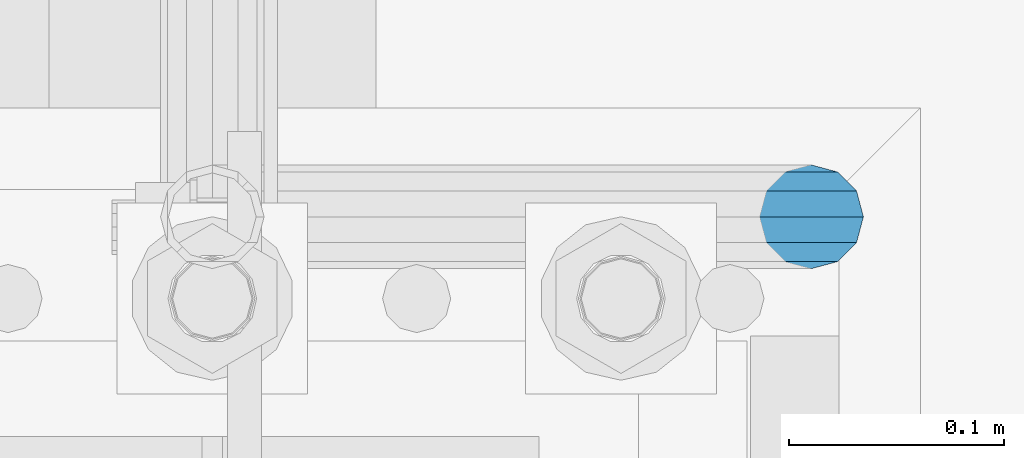
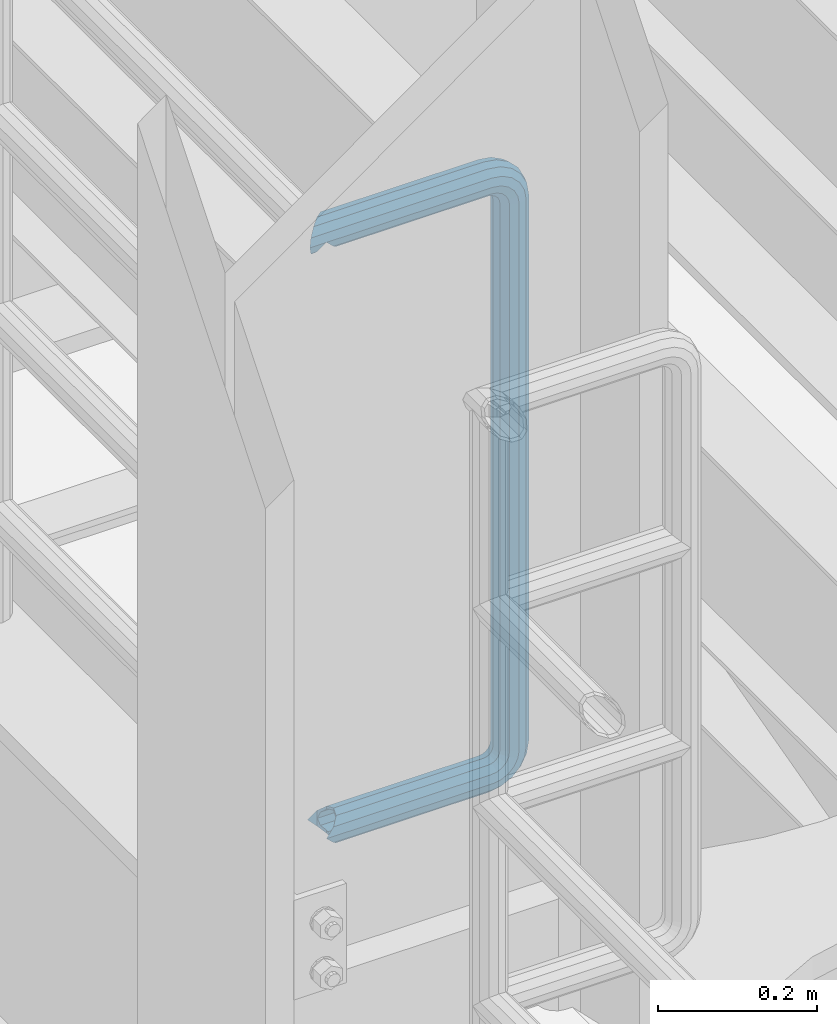
# One storey, part 958 of 1876: 1 beam, 1 element without a shape of its own.
"""IFC2X3 building model written with IfcOpenShell, lengths in millimetres."""

from ifc_helpers import new_model, si_unit, frame, origin_with_axes, place, context, subcontext, project, spatial, faceted_brep, material, type_object, element, aggregate, save


model = new_model("IFC2X3")

# Units and contexts
model_context = context("Model", 3, precision=1e-05, world=origin_with_axes())
body_context = subcontext(model_context, "Body", "Model", "MODEL_VIEW")
ifc_project = project(units=[si_unit("LENGTHUNIT", "METRE", prefix="MILLI"), si_unit("AREAUNIT", "SQUARE_METRE"), si_unit("VOLUMEUNIT", "CUBIC_METRE"), si_unit("MASSUNIT", "GRAM", prefix="KILO"), si_unit("TIMEUNIT", "SECOND"), si_unit("PLANEANGLEUNIT", "RADIAN"), si_unit("SOLIDANGLEUNIT", "STERADIAN"), si_unit("THERMODYNAMICTEMPERATUREUNIT", "DEGREE_CELSIUS"), si_unit("LUMINOUSINTENSITYUNIT", "LUMEN")], contexts=[model_context])

# Site, building, storey
site_placement = place(None, origin_with_axes())
site = spatial("IfcSite", under=ifc_project, at=site_placement, CompositionType="ELEMENT")
building_placement = place(site_placement, origin_with_axes())
building = spatial("IfcBuilding", under=site, at=building_placement, Name="Undefined", CompositionType="ELEMENT")
storey_placement = place(building_placement, origin_with_axes())
storey = spatial("IfcBuildingStorey", under=building, at=storey_placement, Name="Undefined", CompositionType="ELEMENT", Elevation=0.0)

# Assembly, beam
assembly_placement = place(storey_placement, origin_with_axes())
assembly = element("IfcElementAssembly", 1, at=assembly_placement, inside=storey, Name="RAIL", AssemblyPlace="NOTDEFINED", PredefinedType="RIGID_FRAME")
ifc_material = material()
beam_type = type_object("IfcBeamType", Name="PIPE1-1/2SCH40", PredefinedType="NOTDEFINED")
beam_placement = place(assembly_placement, frame((-5.00222085975111e-12, -4356.1, 9229.725), z_axis=(0.0, 0.0, 1.0), x_axis=(1.0, 0.0, 0.0)))
beam = element("IfcBeam", 2, at=beam_placement, type_object=beam_type, material=ifc_material, Name="RAIL", ObjectType="PIPE1-1/2SCH40", context=body_context, shape_type="Brep", body=[
    faceted_brep([(16.4810964966631, 16.4810964966564, -11.4500249345219), (16.481099754581, 16.4810997545774, -16.4810932387409), (20.8971929933249, 12.0650000000005, -20.8971929933177), (20.8971929933249, 12.0650000000005, -15.8661214311796), (0.0, -24.1299999999992, 0.0), (12.0650000000014, -20.8971929933186, 0.0), (12.0650000000064, -20.8971929933177, -12.0649999999987), (-12.0650000000096, -20.8971929933177, -12.0649999999987), (-12.0649999999986, -20.8971929933186, 0.0), (-16.481093238739, -16.4810932387427, -16.4810997545756), (-16.4810964966554, -16.4810964966618, -11.4500249345183), (-15.2545715621367, -17.7076214311801, -10.2235000000001), (-12.5151929933171, -20.4470000000001, 0.0), (12.5151929933249, -20.4470000000001, 0.0), (20.8971929933249, -12.0650000000005, -15.8661214311796), (20.8971929933249, -12.0650000000005, -20.8971929933177), (15.2545715621445, -17.7076214311801, -10.2235000000001), (24.1300000000063, 0.0, -20.4470000000001), (24.1300000000063, 0.0, -24.130000000001), (21.3906214311868, -10.2235000000001, -17.7076214311819), (21.3906214311868, 10.2235000000001, -17.7076214311819), (1.20714750983051e-12, 24.1299999999974, -914.399963378906), (12.0650000000014, 20.8971929933159, -926.464963378905), (12.0650000000014, 20.8971929933177, -902.334963378908), (12.0650000000014, -20.8971929933195, -902.334963378908), (12.0650000000014, -20.8971929933195, -926.464963378905), (1.52133659548828e-12, -24.130000000001, -914.399963378906), (20.8971929933199, -12.0650000000023, -893.502770385589), (20.8971929933199, -12.0650000000005, -898.533841947723), (15.2545715621378, -17.7076214311819, -904.176463378906), (12.5151929933181, -20.4470000000019, -914.399963378906), (15.2545715621376, -17.7076214311819, -924.623463378906), (20.8971929933199, -12.0650000000005, -930.26608481009), (20.8971929933199, -12.0650000000023, -935.297156372224), (24.1300000000014, -1.81898940354586e-12, -934.846963378906), (24.1300000000014, -1.81898940354586e-12, -938.529963378907), (21.3906214311813, -10.2235000000019, -932.107584810088), (21.3906214311823, 10.2234999999982, -932.107584810088), (20.8971929933199, 12.0650000000005, -930.266084810086), (20.8971929933199, 12.0649999999987, -935.297156372224), (15.2545715621413, 17.7076214311783, -924.623463378906), (12.5151929933216, 20.4469999999983, -914.399963378906), (15.2545715621411, 17.7076214311783, -904.176463378906), (20.8971929933199, 12.0650000000005, -898.533841947727), (20.8971929933199, 12.0649999999987, -893.502770385589), (21.3906214311822, 10.2234999999982, -896.692341947724), (24.1300000000014, 0.0, -893.952963378906), (24.1300000000014, 0.0, -890.269963378905), (21.3906214311814, -10.2235000000019, -896.692341947724), (241.299995422363, -20.8971929933177, 12.0649999999987), (241.299995422363, -24.1299999999992, 0.0), (253.073542436527, -24.1299999999992, -1.86474665447167), (256.801832473661, -20.8971929933177, 9.60975021462946), (241.299995422363, -12.0650000000005, 20.8971929933177), (259.531130206197, -12.0650000000005, 18.0096649141014), (241.299995422363, 0.0, 24.130000000001), (260.530122510796, 0.0, 21.084247083727), (241.299995422363, 12.0650000000005, 20.8971929933177), (259.531130206197, 12.0650000000005, 18.0096649141014), (241.299995422363, 20.8971929933177, 12.0649999999987), (256.801832473661, 20.8971929933177, 9.60975021462946), (241.299995422363, 24.1299999999992, 0.0), (253.073542436527, 24.1299999999992, -1.86474665447167), (241.299995422363, 20.8971929933177, -12.0649999999987), (249.345252399393, 20.8971929933177, -13.3392435235728), (241.299995422363, 12.0650000000005, -20.8971929933177), (246.615954666858, 12.0650000000005, -21.7391582230448), (241.299995422363, 0.0, -24.130000000001), (245.616962362259, 0.0, -24.8137403926739), (241.299995422363, -12.0650000000005, -20.8971929933177), (246.615954666858, -12.0650000000005, -21.7391582230448), (241.299995422363, -20.8971929933177, -12.0649999999987), (249.345252399393, -20.8971929933177, -13.3392435235728), (267.334993896485, 20.8971929933177, -38.0999984741211), (279.399993896485, 24.1299999999992, -38.0999984741211), (279.399993896484, 24.1299999999992, -876.299964904785), (267.334993896484, 20.8971929933177, -876.299964904785), (291.464993896486, 20.8971929933177, -38.0999984741211), (291.464993896484, 20.8971929933177, -876.299964904785), (300.297186889804, 12.0650000000005, -38.0999984741211), (300.297186889803, 12.0650000000005, -876.299964904785), (303.529993896486, 0.0, -38.0999984741211), (303.529993896484, 0.0, -876.299964904785), (300.297186889804, -12.0650000000005, -38.0999984741211), (300.297186889803, -12.0650000000005, -876.299964904785), (291.464993896486, -20.8971929933177, -38.0999984741211), (291.464993896484, -20.8971929933177, -876.299964904785), (279.399993896484, -24.1299999999992, -38.0999984741211), (279.399993896484, -24.1299999999992, -876.299964904785), (267.334993896485, -20.8971929933177, -38.0999984741211), (267.334993896484, -20.8971929933177, -876.299964904785), (258.502800903167, -12.0650000000005, -38.0999984741211), (258.502800903166, -12.0650000000005, -876.299964904785), (255.269993896485, 0.0, -38.0999984741211), (255.269993896484, 0.0, -876.299964904785), (258.502800903167, 12.0650000000005, -38.0999984741211), (258.502800903166, 12.0650000000005, -876.299964904785), (257.660835673438, 12.0650000000005, -881.615924149282), (254.586253503809, 0.0, -880.616931844681), (257.660835673438, -12.0650000000005, -881.615924149282), (266.06075037291, -20.8971929933177, -884.345221881817), (277.535247242011, -24.130000000001, -888.073511918952), (289.009744111112, -20.8971929933195, -891.801801956084), (297.409658810584, -12.0650000000005, -894.531099688622), (300.484240980214, 0.0, -895.53009199322), (297.409658810584, 12.0650000000005, -894.531099688622), (289.009744111112, 20.8971929933177, -891.801801956084), (277.535247242011, 24.1299999999992, -888.073511918952), (266.06075037291, 20.8971929933177, -884.345221881817), (241.299995422364, -1.81898940354586e-12, -938.529963378911), (241.299995422364, -12.0650000000005, -935.297156372228), (241.299995422364, -20.8971929933195, -926.464963378909), (241.299995422363, -24.130000000001, -914.399963378906), (241.299995422363, -20.8971929933195, -902.334963378908), (241.299995422363, -12.0650000000005, -893.502770385589), (241.299995422363, 0.0, -890.269963378909), (241.299995422364, 20.8971929933177, -926.464963378909), (241.299995422364, 12.0649999999987, -935.297156372228), (241.299995422364, 24.1299999999992, -914.39996337891), (241.299995422363, 20.8971929933177, -902.334963378908), (241.299995422363, 12.0649999999987, -893.502770385589), (260.530122510801, 0.0, -935.484210462637), (259.531130206202, 12.0649999999987, -932.409628293008), (259.531130206201, -12.0650000000005, -932.409628293008), (256.801832473666, -20.8971929933195, -924.009713593536), (253.07354243653, -24.130000000001, -912.535216724435), (249.345252399395, -20.8971929933195, -901.060719855333), (246.615954666859, -12.0650000000005, -892.660805155861), (245.61696236226, 0.0, -889.586222986232), (246.615954666859, 12.0649999999987, -892.660805155861), (249.345252399395, 20.8971929933177, -901.060719855333), (253.07354243653, 24.1299999999992, -912.535216724435), (256.801832473666, 20.8971929933177, -924.009713593536), (275.977674493594, 12.0649999999987, -924.029695422345), (270.786241706733, 20.8971929933177, -916.884301193139), (277.877870775644, 0.0, -926.645091230272), (275.977674493608, -12.0650000000005, -924.029695422334), (270.786241706733, -20.8971929933195, -916.884301193139), (263.694612637823, -24.130000000001, -907.123511156005), (256.602983568912, -20.8971929933195, -897.362721118872), (251.411550782037, -12.0650000000005, -890.21732688968), (249.511354500001, 0.0, -887.601931081743), (251.411550782037, 12.0650000000005, -890.21732688968), (256.602983568912, 20.8971929933177, -897.362721118872), (263.694612637823, 24.1299999999992, -907.123511156005), (281.884331710718, 20.8971929933177, -905.786211189152), (272.123541673585, 24.1299999999992, -898.694582120243), (289.029725939912, 12.0650000000005, -910.977643976028), (291.645121747852, 0.0, -912.877840258065), (289.029725939912, -12.0650000000005, -910.977643976028), (281.884331710718, -20.8971929933195, -905.786211189152), (272.123541673585, -24.130000000001, -898.694582120243), (262.362751636451, -20.8971929933195, -891.602953051333), (255.217357407258, -12.0650000000005, -886.411520264461), (252.601961599318, 0.0, -884.511323982424), (255.217357407258, 12.0650000000005, -886.411520264461), (262.362751636451, 20.8971929933177, -891.602953051333), (266.060750372911, 20.8971929933177, -30.0547414970897), (257.660835673439, 12.0650000000005, -32.7840392296275), (277.535247242011, 24.1299999999992, -26.3264514599541), (289.009744111112, 20.8971929933177, -22.5981614228222), (297.409658810584, 12.0650000000005, -19.8688636902843), (300.484240980213, 0.0, -18.8698713856866), (297.409658810584, -12.0650000000005, -19.8688636902843), (289.009744111112, -20.8971929933177, -22.5981614228222), (277.535247242011, -24.1299999999992, -26.3264514599541), (266.060750372911, -20.8971929933177, -30.0547414970897), (257.660835673439, -12.0650000000005, -32.7840392296275), (254.58625350381, 0.0, -33.7830315342253), (255.217357407257, 12.0650000000005, -27.9884431144455), (252.601961599318, 0.0, -29.8886393964822), (262.362751636451, 20.8971929933177, -22.7970103275729), (272.123541673583, 24.1299999999992, -15.7053812586601), (281.884331710716, 20.8971929933177, -8.61375218975081), (289.029725939909, 12.0650000000005, -3.42231940287456), (291.645121747848, 0.0, -1.52212312084157), (289.029725939909, -12.0650000000005, -3.42231940287456), (281.884331710716, -20.8971929933177, -8.61375218975081), (272.123541673583, -24.1299999999992, -15.7053812586601), (262.362751636451, -20.8971929933177, -22.7970103275729), (255.217357407257, -12.0650000000005, -27.9884431144455), (249.511354500002, 0.0, -26.7980322971671), (251.411550782037, -12.0650000000005, -24.1826364892258), (251.411550782037, 12.0650000000005, -24.1826364892258), (256.602983568912, 20.8971929933177, -17.037242260034), (263.694612637822, 24.1299999999992, -7.27645222290084), (270.786241706732, 20.8971929933177, 2.48433781423228), (275.977674493607, 12.0650000000005, 9.62973204342416), (277.877870775642, 0.0, 12.2451278513654), (275.977674493607, -12.0650000000005, 9.62973204342416), (270.786241706732, -20.8971929933177, 2.48433781423228), (263.694612637822, -24.1299999999992, -7.27645222290084), (256.602983568912, -20.8971929933177, -17.037242260034), (20.8971929933232, 20.8971929933177, -12.0649999999987), (24.1300000000047, 24.1299999999992, 0.0), (20.8971929933232, 20.8971929933177, 12.0649999999987), (12.0650000000041, 12.0650000000005, 20.8971929933177), (-1.45519152283669e-11, 0.0, 24.130000000001), (-12.0649999999951, -12.0650000000005, 20.8971929933177), (-20.8971929933141, -20.8971929933177, 12.0649999999987), (-24.1299999999956, -24.1299999999992, 0.0), (-20.8971929933141, -20.8971929933177, -12.0649999999987), (-17.7076214311755, -17.7076214311801, -10.2235000000001), (-20.4469999999956, -20.4470000000001, 0.0), (-17.7076214311755, -17.7076214311801, 10.2235000000001), (241.299995422363, -17.7076214311801, 10.2235000000001), (241.299995422363, -20.4470000000001, 0.0), (241.299995422363, -17.7076214311801, -10.2235000000001), (241.299995422363, -10.2235000000001, -17.7076214311819), (241.299995422363, 0.0, -20.4470000000001), (241.299995422363, 0.0, 20.4470000000001), (241.299995422363, -10.2235000000001, 17.7076214311819), (-10.2234999999955, -10.2235000000001, 17.7076214311819), (-1.45519152283669e-11, 0.0, 20.4470000000001), (241.299995422363, 10.2235000000001, 17.7076214311819), (10.2235000000046, 10.2235000000001, 17.7076214311819), (241.299995422363, 17.7076214311801, 10.2235000000001), (17.7076214311846, 17.7076214311801, 10.2235000000001), (241.299995422363, 20.4470000000001, 0.0), (20.4470000000047, 20.4470000000001, 0.0), (241.299995422363, 17.7076214311801, -10.2235000000001), (17.7076214311846, 17.7076214311801, -10.2235000000001), (241.299995422363, 10.2235000000001, -17.7076214311819), (258.545498388721, -10.2235000000001, 14.9762020957387), (256.23277767852, -17.7076214311801, 7.85837963987069), (253.073542436527, -20.4470000000001, -1.86474665447167), (249.914307194535, -17.7076214311801, -11.5878729488177), (247.601586484334, -10.2235000000001, -18.7056954046857), (246.755071952542, 0.0, -21.31099924316), (247.601586484334, 10.2235000000001, -18.7056954046857), (249.914307194535, 17.7076214311801, -11.5878729488177), (253.073542436527, 20.4470000000001, -1.86474665447167), (256.23277767852, 17.7076214311801, 7.85837963987069), (258.545498388721, 10.2235000000001, 14.9762020957387), (259.392012920513, 0.0, 17.5815059342131), (275.713057691449, 0.0, 9.26551826108334), (274.10289136825, -10.2235000000001, 7.04931444488102), (274.10289136825, 10.2235000000001, 7.04931444488102), (269.703835164635, 17.7076214311801, 0.994533019089431), (263.694612637822, 20.4470000000001, -7.27645222290084), (257.685390111009, 17.7076214311801, -15.5474374648911), (253.286333907394, 10.2235000000001, -21.6022188906827), (251.676167584195, 0.0, -23.818422706885), (253.286333907394, -10.2235000000001, -21.6022188906827), (257.685390111009, -17.7076214311801, -15.5474374648911), (263.694612637822, -20.4470000000001, -7.27645222290084), (269.703835164635, -17.7076214311801, 0.994533019089431), (286.449308341364, -10.2235000000001, -5.29710252823133), (280.394526915574, -17.7076214311801, -9.69615873184739), (288.665512157566, 0.0, -3.68693620503473), (286.449308341364, 10.2235000000001, -5.29710252823133), (280.394526915574, 17.7076214311801, -9.69615873184739), (272.123541673583, 20.4470000000001, -15.7053812586601), (263.852556431592, 17.7076214311801, -21.7146037854764), (257.797775005802, 10.2235000000001, -26.1136599890888), (255.581571189601, 0.0, -27.723826312289), (257.797775005802, -10.2235000000001, -26.1136599890888), (263.852556431592, -17.7076214311801, -21.7146037854764), (272.123541673583, -20.4470000000001, -15.7053812586601), (287.258373536355, -17.7076214311801, -23.1672162179639), (277.535247242011, -20.4470000000001, -26.3264514599541), (294.376195992223, -10.2235000000001, -20.8544955077632), (296.981499830698, 0.0, -20.00798097597), (294.376195992223, 10.2235000000001, -20.8544955077632), (287.258373536355, 17.7076214311801, -23.1672162179639), (277.535247242011, 20.4470000000001, -26.3264514599541), (267.812120947668, 17.7076214311801, -29.485686701948), (260.6942984918, 10.2235000000001, -31.7984074121487), (258.088994653325, 0.0, -32.6449219439419), (260.6942984918, -10.2235000000001, -31.7984074121487), (267.812120947668, -17.7076214311801, -29.485686701948), (279.399993896484, -20.4470000000001, -38.0999984741211), (269.176493896485, -17.7076214311801, -38.0999984741211), (289.623493896486, -17.7076214311801, -38.0999984741211), (297.107615327666, -10.2235000000001, -38.0999984741211), (299.846993896486, 0.0, -38.0999984741211), (297.107615327666, 10.2235000000001, -38.0999984741211), (289.623493896486, 17.7076214311801, -38.0999984741211), (279.399993896485, 20.4470000000001, -38.0999984741211), (269.176493896485, 17.7076214311801, -38.0999984741211), (261.692372465305, 10.2235000000001, -38.0999984741211), (258.952993896485, 0.0, -38.0999984741211), (261.692372465305, -10.2235000000001, -38.0999984741211), (269.176493896484, -17.7076214311801, -876.299964904785), (261.692372465304, -10.2235000000001, -876.299964904785), (258.952993896484, 0.0, -876.299964904785), (261.692372465304, 10.2235000000001, -876.299964904785), (269.176493896484, 17.7076214311801, -876.299964904785), (279.399993896484, 20.4470000000001, -876.299964904785), (289.623493896484, 17.7076214311801, -876.299964904785), (297.107615327665, 10.2235000000001, -876.299964904785), (299.846993896484, 0.0, -876.299964904785), (297.107615327665, -10.2235000000001, -876.299964904785), (289.623493896484, -17.7076214311801, -876.299964904785), (279.399993896484, -20.4470000000001, -876.299964904785), (277.535247242011, -20.4470000000001, -888.073511918952), (267.812120947667, -17.7076214311801, -884.914276676958), (260.694298491799, -10.2235000000001, -882.601555966758), (258.088994653324, 0.0, -881.755041434964), (260.694298491799, 10.2235000000001, -882.601555966758), (267.812120947668, 17.7076214311801, -884.914276676958), (277.535247242011, 20.4470000000001, -888.073511918952), (287.258373536355, 17.7076214311801, -891.232747160942), (294.376195992223, 10.2235000000001, -893.545467871143), (296.981499830699, 0.0, -894.391982402936), (294.376195992223, -10.2235000000001, -893.545467871143), (287.258373536355, -17.7076214311801, -891.232747160942), (280.394526915577, -17.7076214311801, -904.703804647055), (272.123541673585, -20.4470000000001, -898.694582120243), (286.449308341367, -10.2235000000001, -909.102860850671), (288.665512157569, 0.0, -910.713027173868), (286.449308341367, 10.2235000000001, -909.102860850671), (280.394526915577, 17.7076214311801, -904.703804647055), (272.123541673585, 20.4470000000001, -898.694582120243), (263.852556431593, 17.7076214311801, -892.68535959343), (257.797775005802, 10.2235000000001, -888.286303389817), (255.581571189601, 0.0, -886.676137066617), (257.797775005802, -10.2235000000001, -888.286303389817), (263.852556431593, -17.7076214311801, -892.68535959343), (263.694612637823, -20.4470000000001, -907.123511156005), (257.685390111009, -17.7076214311801, -898.852525914015), (269.703835164636, -17.7076214311801, -915.394496397999), (274.102891368238, -10.2235000000001, -921.449277823798), (275.71305769145, 0.0, -923.66548163999), (274.102891368251, 10.2235000000001, -921.449277823787), (269.703835164636, 17.7076214311801, -915.394496397999), (263.694612637823, 20.4470000000001, -907.123511156005), (257.685390111009, 17.7076214311801, -898.852525914015), (253.286333907394, 10.2235000000001, -892.797744488227), (251.676167584195, 0.0, -890.581540672025), (253.286333907394, -10.2235000000001, -892.797744488227), (249.914307194537, -17.7076214311801, -902.812090430092), (247.601586484335, -10.2235000000001, -895.694267974224), (253.07354243653, -20.4470000000001, -912.535216724435), (256.232777678524, -17.7076214311819, -922.258343018777), (258.545498388725, -10.2235000000001, -929.376165474645), (259.392012920517, 0.0, -931.981469313119), (258.545498388725, 10.2235000000001, -929.376165474645), (256.232777678524, 17.7076214311801, -922.258343018777), (253.07354243653, 20.4470000000001, -912.535216724435), (249.914307194537, 17.7076214311801, -902.812090430092), (247.601586484335, 10.2235000000001, -895.694267974224), (246.755071952543, 0.0, -893.088964135746), (241.299995422363, -10.2235000000001, -896.692341947728), (241.299995422363, 0.0, -893.95296337891), (241.299995422363, -17.7076214311819, -904.17646337891), (241.299995422363, -20.4470000000001, -914.399963378906), (241.299995422364, -17.7076214311819, -924.62346337891), (241.299995422364, -10.2235000000001, -932.107584810088), (241.299995422364, -1.81898940354586e-12, -934.84696337891), (241.299995422364, 10.2234999999982, -932.107584810088), (241.299995422364, 17.7076214311801, -924.62346337891), (241.299995422364, 20.4470000000001, -914.39996337891), (241.299995422363, 17.7076214311801, -904.17646337891), (241.299995422363, 10.2235000000001, -896.692341947728)], [[[0, 1, 2, 3]], [[4, 5, 6]], [[7, 8, 4]], [[9, 10, 11, 12, 8, 7]], [[13, 5, 4, 8, 12]], [[14, 15, 6, 5, 13, 16]], [[17, 18, 15, 14, 19]], [[20, 3, 2, 18, 17]], [[21, 22, 23]], [[24, 25, 26]], [[27, 28, 29, 30, 31, 32, 33, 25, 24]], [[34, 35, 33, 32, 36]], [[37, 38, 39, 35, 34]], [[23, 22, 39, 38, 40, 41, 42, 43, 44]], [[44, 43, 45, 46, 47]], [[47, 46, 48, 28, 27]], [[49, 50, 51, 52]], [[53, 49, 52, 54]], [[55, 53, 54, 56]], [[57, 55, 56, 58]], [[59, 57, 58, 60]], [[61, 59, 60, 62]], [[63, 61, 62, 64]], [[65, 63, 64, 66]], [[67, 65, 66, 68]], [[69, 67, 68, 70]], [[71, 69, 70, 72]], [[73, 74, 75, 76]], [[74, 77, 78, 75]], [[77, 79, 80, 78]], [[79, 81, 82, 80]], [[81, 83, 84, 82]], [[83, 85, 86, 84]], [[85, 87, 88, 86]], [[87, 89, 90, 88]], [[89, 91, 92, 90]], [[91, 93, 94, 92]], [[93, 95, 96, 94]], [[94, 96, 97, 98]], [[92, 94, 98, 99]], [[90, 92, 99, 100]], [[88, 90, 100, 101]], [[86, 88, 101, 102]], [[84, 86, 102, 103]], [[82, 84, 103, 104]], [[80, 82, 104, 105]], [[78, 80, 105, 106]], [[75, 78, 106, 107]], [[76, 75, 107, 108]], [[109, 110, 33, 35]], [[110, 111, 25, 33]], [[111, 112, 26, 25]], [[112, 113, 24, 26]], [[113, 114, 27, 24]], [[114, 115, 47, 27]], [[116, 117, 39, 22]], [[118, 116, 22, 21]], [[119, 118, 21, 23]], [[120, 119, 23, 44]], [[115, 120, 44, 47]], [[117, 109, 35, 39]], [[121, 109, 117, 122]], [[123, 110, 109, 121]], [[124, 111, 110, 123]], [[125, 112, 111, 124]], [[126, 113, 112, 125]], [[127, 114, 113, 126]], [[128, 115, 114, 127]], [[129, 120, 115, 128]], [[130, 119, 120, 129]], [[131, 118, 119, 130]], [[132, 116, 118, 131]], [[122, 117, 116, 132]], [[133, 122, 132, 134]], [[135, 121, 122, 133]], [[136, 123, 121, 135]], [[137, 124, 123, 136]], [[138, 125, 124, 137]], [[139, 126, 125, 138]], [[140, 127, 126, 139]], [[141, 128, 127, 140]], [[142, 129, 128, 141]], [[143, 130, 129, 142]], [[144, 131, 130, 143]], [[134, 132, 131, 144]], [[145, 134, 144, 146]], [[147, 133, 134, 145]], [[148, 135, 133, 147]], [[149, 136, 135, 148]], [[150, 137, 136, 149]], [[151, 138, 137, 150]], [[152, 139, 138, 151]], [[153, 140, 139, 152]], [[154, 141, 140, 153]], [[155, 142, 141, 154]], [[156, 143, 142, 155]], [[146, 144, 143, 156]], [[107, 146, 156, 108]], [[106, 145, 146, 107]], [[105, 147, 145, 106]], [[104, 148, 147, 105]], [[103, 149, 148, 104]], [[102, 150, 149, 103]], [[101, 151, 150, 102]], [[100, 152, 151, 101]], [[99, 153, 152, 100]], [[98, 154, 153, 99]], [[97, 155, 154, 98]], [[108, 156, 155, 97]], [[96, 76, 108, 97]], [[95, 73, 76, 96]], [[157, 73, 95, 158]], [[159, 74, 73, 157]], [[160, 77, 74, 159]], [[161, 79, 77, 160]], [[162, 81, 79, 161]], [[163, 83, 81, 162]], [[164, 85, 83, 163]], [[165, 87, 85, 164]], [[166, 89, 87, 165]], [[167, 91, 89, 166]], [[168, 93, 91, 167]], [[158, 95, 93, 168]], [[169, 158, 168, 170]], [[171, 157, 158, 169]], [[172, 159, 157, 171]], [[173, 160, 159, 172]], [[174, 161, 160, 173]], [[175, 162, 161, 174]], [[176, 163, 162, 175]], [[177, 164, 163, 176]], [[178, 165, 164, 177]], [[179, 166, 165, 178]], [[180, 167, 166, 179]], [[170, 168, 167, 180]], [[181, 170, 180, 182]], [[183, 169, 170, 181]], [[184, 171, 169, 183]], [[185, 172, 171, 184]], [[186, 173, 172, 185]], [[187, 174, 173, 186]], [[188, 175, 174, 187]], [[189, 176, 175, 188]], [[190, 177, 176, 189]], [[191, 178, 177, 190]], [[192, 179, 178, 191]], [[182, 180, 179, 192]], [[70, 182, 192, 72]], [[68, 181, 182, 70]], [[66, 183, 181, 68]], [[64, 184, 183, 66]], [[62, 185, 184, 64]], [[60, 186, 185, 62]], [[58, 187, 186, 60]], [[56, 188, 187, 58]], [[54, 189, 188, 56]], [[52, 190, 189, 54]], [[51, 191, 190, 52]], [[72, 192, 191, 51]], [[50, 71, 72, 51]], [[71, 50, 4, 6]], [[69, 71, 6, 15]], [[67, 69, 15, 18]], [[65, 67, 18, 2]], [[193, 63, 65, 2, 1]], [[61, 63, 193, 194]], [[59, 61, 194, 195]], [[57, 59, 195, 196]], [[55, 57, 196, 197]], [[53, 55, 197, 198]], [[49, 53, 198, 199]], [[4, 50, 49, 199, 200]], [[200, 201, 7, 4]], [[201, 9, 7]], [[202, 11, 10]], [[202, 203, 12, 11]], [[203, 204, 205, 206, 13, 12]], [[206, 207, 16, 13]], [[16, 207, 208, 19, 14]], [[208, 209, 17, 19]], [[210, 211, 212, 213]], [[214, 210, 213, 215]], [[216, 214, 215, 217]], [[218, 216, 217, 219]], [[220, 218, 219, 221]], [[222, 220, 221, 0, 3, 20]], [[209, 222, 20, 17]], [[221, 219, 217, 215, 213, 212, 204, 203, 202, 10, 9, 201, 200, 199, 198, 197, 196, 195, 194, 193, 1, 0]], [[211, 205, 204, 212]], [[205, 211, 223, 224]], [[206, 205, 224, 225]], [[207, 206, 225, 226]], [[208, 207, 226, 227]], [[209, 208, 227, 228]], [[222, 209, 228, 229]], [[220, 222, 229, 230]], [[218, 220, 230, 231]], [[216, 218, 231, 232]], [[214, 216, 232, 233]], [[210, 214, 233, 234]], [[211, 210, 234, 223]], [[234, 235, 236, 223]], [[233, 237, 235, 234]], [[232, 238, 237, 233]], [[231, 239, 238, 232]], [[230, 240, 239, 231]], [[229, 241, 240, 230]], [[228, 242, 241, 229]], [[227, 243, 242, 228]], [[226, 244, 243, 227]], [[225, 245, 244, 226]], [[224, 246, 245, 225]], [[223, 236, 246, 224]], [[236, 247, 248, 246]], [[235, 249, 247, 236]], [[237, 250, 249, 235]], [[238, 251, 250, 237]], [[239, 252, 251, 238]], [[240, 253, 252, 239]], [[241, 254, 253, 240]], [[242, 255, 254, 241]], [[243, 256, 255, 242]], [[244, 257, 256, 243]], [[245, 258, 257, 244]], [[246, 248, 258, 245]], [[248, 259, 260, 258]], [[247, 261, 259, 248]], [[249, 262, 261, 247]], [[250, 263, 262, 249]], [[251, 264, 263, 250]], [[252, 265, 264, 251]], [[253, 266, 265, 252]], [[254, 267, 266, 253]], [[255, 268, 267, 254]], [[256, 269, 268, 255]], [[257, 270, 269, 256]], [[258, 260, 270, 257]], [[260, 271, 272, 270]], [[259, 273, 271, 260]], [[261, 274, 273, 259]], [[262, 275, 274, 261]], [[263, 276, 275, 262]], [[264, 277, 276, 263]], [[265, 278, 277, 264]], [[266, 279, 278, 265]], [[267, 280, 279, 266]], [[268, 281, 280, 267]], [[269, 282, 281, 268]], [[270, 272, 282, 269]], [[282, 272, 283, 284]], [[281, 282, 284, 285]], [[280, 281, 285, 286]], [[279, 280, 286, 287]], [[278, 279, 287, 288]], [[277, 278, 288, 289]], [[276, 277, 289, 290]], [[275, 276, 290, 291]], [[274, 275, 291, 292]], [[273, 274, 292, 293]], [[271, 273, 293, 294]], [[272, 271, 294, 283]], [[283, 294, 295, 296]], [[284, 283, 296, 297]], [[285, 284, 297, 298]], [[286, 285, 298, 299]], [[287, 286, 299, 300]], [[288, 287, 300, 301]], [[289, 288, 301, 302]], [[290, 289, 302, 303]], [[291, 290, 303, 304]], [[292, 291, 304, 305]], [[293, 292, 305, 306]], [[294, 293, 306, 295]], [[306, 307, 308, 295]], [[305, 309, 307, 306]], [[304, 310, 309, 305]], [[303, 311, 310, 304]], [[302, 312, 311, 303]], [[301, 313, 312, 302]], [[300, 314, 313, 301]], [[299, 315, 314, 300]], [[298, 316, 315, 299]], [[297, 317, 316, 298]], [[296, 318, 317, 297]], [[295, 308, 318, 296]], [[308, 319, 320, 318]], [[307, 321, 319, 308]], [[309, 322, 321, 307]], [[310, 323, 322, 309]], [[311, 324, 323, 310]], [[312, 325, 324, 311]], [[313, 326, 325, 312]], [[314, 327, 326, 313]], [[315, 328, 327, 314]], [[316, 329, 328, 315]], [[317, 330, 329, 316]], [[318, 320, 330, 317]], [[320, 331, 332, 330]], [[319, 333, 331, 320]], [[321, 334, 333, 319]], [[322, 335, 334, 321]], [[323, 336, 335, 322]], [[324, 337, 336, 323]], [[325, 338, 337, 324]], [[326, 339, 338, 325]], [[327, 340, 339, 326]], [[328, 341, 340, 327]], [[329, 342, 341, 328]], [[330, 332, 342, 329]], [[332, 343, 344, 342]], [[331, 345, 343, 332]], [[333, 346, 345, 331]], [[334, 347, 346, 333]], [[335, 348, 347, 334]], [[336, 349, 348, 335]], [[337, 350, 349, 336]], [[338, 351, 350, 337]], [[339, 352, 351, 338]], [[340, 353, 352, 339]], [[341, 354, 353, 340]], [[342, 344, 354, 341]], [[354, 344, 46, 45]], [[42, 353, 354, 45, 43]], [[352, 353, 42, 41]], [[351, 352, 41, 40]], [[350, 351, 40, 38, 37]], [[349, 350, 37, 34]], [[348, 349, 34, 36]], [[31, 347, 348, 36, 32]], [[346, 347, 31, 30]], [[345, 346, 30, 29]], [[343, 345, 29, 28, 48]], [[344, 343, 48, 46]]]),
])
aggregate(assembly, [beam])

save(model, "model.ifc")
